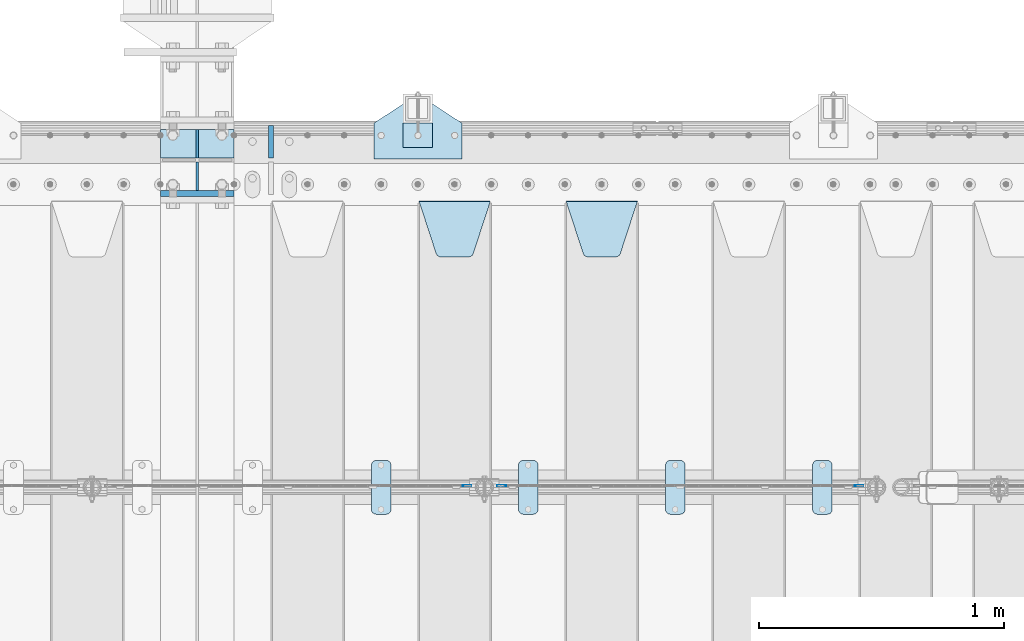
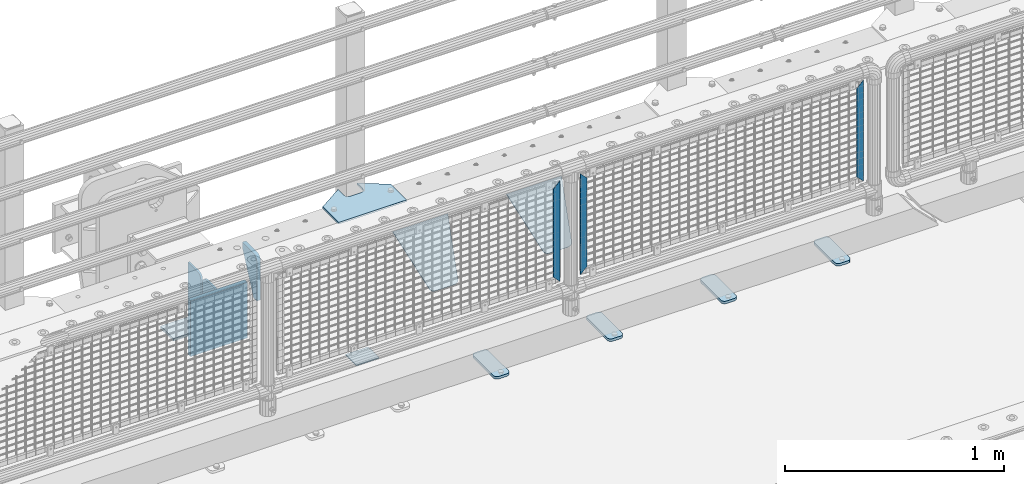
# One storey, part 221 of 247: 16 plates.
"""IFC2X3 building model written with IfcOpenShell, lengths in millimetres."""

from ifc_helpers import new_model, si_unit, frame, origin_with_axes, place, context, subcontext, project, spatial, faceted_brep, material, type_object, element, save


model = new_model("IFC2X3")

# Units and contexts
model_context = context("Model", 3, precision=1e-05, world=origin_with_axes())
body_context = subcontext(model_context, "Body", "Model", "MODEL_VIEW")
ifc_project = project(units=[si_unit("LENGTHUNIT", "METRE", prefix="MILLI"), si_unit("AREAUNIT", "SQUARE_METRE"), si_unit("VOLUMEUNIT", "CUBIC_METRE"), si_unit("MASSUNIT", "GRAM", prefix="KILO"), si_unit("TIMEUNIT", "SECOND"), si_unit("PLANEANGLEUNIT", "RADIAN"), si_unit("SOLIDANGLEUNIT", "STERADIAN"), si_unit("THERMODYNAMICTEMPERATUREUNIT", "DEGREE_CELSIUS"), si_unit("LUMINOUSINTENSITYUNIT", "LUMEN")], contexts=[model_context])

# Site, building, storey
site_placement = place(None, origin_with_axes())
site = spatial("IfcSite", under=ifc_project, at=site_placement, CompositionType="ELEMENT")
building_placement = place(site_placement, origin_with_axes())
building = spatial("IfcBuilding", under=site, at=building_placement, Name="Standard", CompositionType="ELEMENT")
storey_placement = place(building_placement, origin_with_axes())
storey = spatial("IfcBuildingStorey", under=building, at=storey_placement, Name="Undefined", CompositionType="ELEMENT", Elevation=0.0)

# Plates
ifc_material_1 = material(Name="STEEL/S355N")
plate_type_1 = type_object("IfcPlateType", PredefinedType="NOTDEFINED")
plate_1_placement = place(storey_placement, frame((12100.0, 8862.5, -340.0), z_axis=(0.0, 0.0, 1.0), x_axis=(1.0, 0.0, 0.0)))
element("IfcPlate", 1, at=plate_1_placement, inside=storey, type_object=plate_type_1, material=ifc_material_1, context=body_context, shape_type="Brep", body=[
    faceted_brep([(0.0, -12.5, 0.0), (0.0, -12.5, 310.0), (0.0, 12.5, 310.0), (0.0, 12.5, 0.0), (300.0, -12.5, 310.0), (300.0, 12.5, 310.0), (300.0, -12.5, 0.0), (300.0, 12.5, 0.0)], [[[0, 1, 2, 3]], [[1, 4, 5, 2]], [[4, 6, 7, 5]], [[6, 0, 3, 7]], [[5, 7, 3, 2]], [[6, 4, 1, 0]]]),
])
plate_type_2 = type_object("IfcPlateType", PredefinedType="NOTDEFINED")
plate_2_placement = place(storey_placement, frame((12100.0, 9008.0, -343.0), z_axis=(0.0, 1.0, 0.0), x_axis=(1.0, 0.0, 0.0)))
element("IfcPlate", 2, at=plate_2_placement, inside=storey, type_object=plate_type_2, material=ifc_material_1, context=body_context, shape_type="Brep", body=[
    faceted_brep([(0.0, -7.0, 0.0), (0.0, -7.0, 117.0), (0.0, 7.0, 117.0), (0.0, 7.0, 0.0), (300.0, -7.0, 117.0), (300.0, 7.0, 117.0), (300.0, -7.0, 0.0), (300.0, 7.0, 0.0)], [[[0, 1, 2, 3]], [[1, 4, 5, 2]], [[4, 6, 7, 5]], [[6, 0, 3, 7]], [[5, 7, 3, 2]], [[6, 4, 1, 0]]]),
])
plate_type_3 = type_object("IfcPlateType", PredefinedType="NOTDEFINED")
for number, where, z_axis, x_axis in (
    (3, (12250.0, 9008.0, -30.0), (0.0, 0.0, -1.0), (0.0, 1.0, 0.0)),
    (4, (12250.0, 8992.0, -30.0), (0.0, 0.0, -1.0), (0.0, -0.999999999999548, -9.5100000000016e-07)),
):
    element("IfcPlate", number, at=place(storey_placement, frame(where, z_axis=z_axis, x_axis=x_axis)), inside=storey, type_object=plate_type_3, material=ifc_material_1, context=body_context, shape_type="Brep", body=[
        faceted_brep([(0.0, -5.0, 30.0), (0.0, -5.0, 306.0), (0.0, 5.0, 306.0), (0.0, 5.0, 30.0), (117.0, -5.0, 306.0), (117.0, 5.0, 306.0), (117.0, -5.0, 0.0), (117.0, 5.0, 0.0), (30.0, -5.0, 0.0), (30.0, 5.0, 0.0), (24.7905546699922, -5.0, 0.455767409633758), (24.7905546699922, 5.0, 0.455767409633758), (19.73939570023, -5.0, 1.80922137642275), (19.73939570023, 5.0, 1.80922137642275), (15.0, -5.0, 4.01923788646684), (15.0, 5.0, 4.01923788646684), (10.716371709404, -5.0, 7.01866670643066), (10.716371709404, 5.0, 7.01866670643066), (7.01866670643085, -5.0, 10.7163717094038), (7.01866670643085, 5.0, 10.7163717094038), (4.01923788646673, -5.0, 15.0), (4.01923788646673, 5.0, 15.0), (1.80922137642256, -5.0, 19.7393957002299), (1.80922137642256, 5.0, 19.7393957002299), (0.455767409633609, -5.0, 24.7905546699921), (0.455767409633609, 5.0, 24.7905546699921)], [[[0, 1, 2, 3]], [[1, 4, 5, 2]], [[4, 6, 7, 5]], [[6, 8, 9, 7]], [[8, 10, 11, 9]], [[10, 12, 13, 11]], [[12, 14, 15, 13]], [[14, 16, 17, 15]], [[16, 18, 19, 17]], [[18, 20, 21, 19]], [[20, 22, 23, 21]], [[22, 24, 25, 23]], [[24, 0, 3, 25]], [[5, 7, 9, 11, 13, 15, 17, 19, 21, 23, 25, 3, 2]], [[24, 22, 20, 18, 16, 14, 12, 10, 8, 6, 4, 1, 0]]]),
    ])
ifc_material_2 = material(Name="STEEL/S355J2")
plate_type_4 = type_object("IfcPlateType", PredefinedType="NOTDEFINED")
plate_3_placement = place(storey_placement, frame((14760.0, 7774.5, 21.0199999999977), z_axis=(1.0, 0.0, 0.0), x_axis=(0.0, -0.999999999999548, -9.5100000000016e-07)))
element("IfcPlate", 5, at=plate_3_placement, inside=storey, type_object=plate_type_4, material=ifc_material_2, context=body_context, shape_type="Brep", body=[
    faceted_brep([(0.0, -7.0, 20.0), (0.0, -7.0, 60.0), (0.0, 7.0, 60.0), (0.0, 7.0, 20.0), (0.384294391935327, -7.0, 63.9018064403226), (0.384294391935327, 7.0, 63.9018064403226), (1.52240934977453, -7.0, 67.6536686473009), (1.52240934977453, 7.0, 67.6536686473009), (3.37060775394912, -7.0, 71.1114046603925), (3.37060775394912, 7.0, 71.1114046603925), (5.85786437626939, -7.0, 74.1421356237315), (5.85786437626939, 7.0, 74.1421356237315), (8.8885953396084, -7.0, 76.6293922460518), (8.8885953396084, 7.0, 76.6293922460518), (12.3463313526981, -7.0, 78.4775906502255), (12.3463313526981, 7.0, 78.4775906502255), (16.0981935596774, -7.0, 79.6157056080647), (16.0981935596774, 7.0, 79.6157056080647), (20.0, -7.0, 80.0), (20.0, 7.0, 80.0), (200.0, -7.0, 80.0), (200.0, 7.0, 80.0), (203.901806440323, -7.0, 79.6157056080647), (203.901806440323, 7.0, 79.6157056080647), (207.653668647302, -7.0, 78.4775906502255), (207.653668647302, 7.0, 78.4775906502255), (211.111404660392, -7.0, 76.6293922460518), (211.111404660392, 7.0, 76.6293922460518), (214.142135623731, -7.0, 74.1421356237315), (214.142135623731, 7.0, 74.1421356237315), (216.629392246051, -7.0, 71.1114046603925), (216.629392246051, 7.0, 71.1114046603925), (218.477590650225, -7.0, 67.6536686473009), (218.477590650225, 7.0, 67.6536686473009), (219.615705608065, -7.0, 63.9018064403226), (219.615705608065, 7.0, 63.9018064403226), (220.0, -7.0, 60.0), (220.0, 7.0, 60.0), (220.0, -7.0, 20.0), (220.0, 7.0, 20.0), (219.615705608065, -7.0, 16.0981935596774), (219.615705608065, 7.0, 16.0981935596774), (218.477590650225, -7.0, 12.3463313526991), (218.477590650225, 7.0, 12.3463313526991), (216.629392246051, -7.0, 8.88859533960749), (216.629392246051, 7.0, 8.88859533960749), (214.142135623731, -7.0, 5.85786437626848), (214.142135623731, 7.0, 5.85786437626848), (211.111404660392, -7.0, 3.37060775394821), (211.111404660392, 7.0, 3.37060775394821), (207.653668647302, -7.0, 1.52240934977453), (207.653668647302, 7.0, 1.52240934977453), (203.901806440323, -7.0, 0.384294391935327), (203.901806440323, 7.0, 0.384294391935327), (200.0, -7.0, 0.0), (200.0, 7.0, 0.0), (20.0, -7.0, 0.0), (20.0, 7.0, 0.0), (16.0981935596774, -7.0, 0.384294391935327), (16.0981935596774, 7.0, 0.384294391935327), (12.3463313526981, -7.0, 1.52240934977453), (12.3463313526981, 7.0, 1.52240934977453), (8.8885953396084, -7.0, 3.37060775394821), (8.8885953396084, 7.0, 3.37060775394821), (5.85786437626939, -7.0, 5.85786437626848), (5.85786437626939, 7.0, 5.85786437626848), (3.37060775394912, -7.0, 8.88859533960749), (3.37060775394912, 7.0, 8.88859533960749), (1.52240934977453, -7.0, 12.3463313526991), (1.52240934977453, 7.0, 12.3463313526991), (0.384294391935327, -7.0, 16.0981935596774), (0.384294391935327, 7.0, 16.0981935596774)], [[[0, 1, 2, 3]], [[1, 4, 5, 2]], [[4, 6, 7, 5]], [[6, 8, 9, 7]], [[8, 10, 11, 9]], [[10, 12, 13, 11]], [[12, 14, 15, 13]], [[14, 16, 17, 15]], [[16, 18, 19, 17]], [[18, 20, 21, 19]], [[20, 22, 23, 21]], [[22, 24, 25, 23]], [[24, 26, 27, 25]], [[26, 28, 29, 27]], [[28, 30, 31, 29]], [[30, 32, 33, 31]], [[32, 34, 35, 33]], [[34, 36, 37, 35]], [[36, 38, 39, 37]], [[38, 40, 41, 39]], [[40, 42, 43, 41]], [[42, 44, 45, 43]], [[44, 46, 47, 45]], [[46, 48, 49, 47]], [[48, 50, 51, 49]], [[50, 52, 53, 51]], [[52, 54, 55, 53]], [[54, 56, 57, 55]], [[56, 58, 59, 57]], [[58, 60, 61, 59]], [[60, 62, 63, 61]], [[62, 64, 65, 63]], [[64, 66, 67, 65]], [[66, 68, 69, 67]], [[68, 70, 71, 69]], [[70, 0, 3, 71]], [[5, 7, 9, 11, 13, 15, 17, 19, 21, 23, 25, 27, 29, 31, 33, 35, 37, 39, 41, 43, 45, 47, 49, 51, 53, 55, 57, 59, 61, 63, 65, 67, 69, 71, 3, 2]], [[70, 68, 66, 64, 62, 60, 58, 56, 54, 52, 50, 48, 46, 44, 42, 40, 38, 36, 34, 32, 30, 28, 26, 24, 22, 20, 18, 16, 14, 12, 10, 8, 6, 4, 1, 0]]]),
])
plate_4_placement = place(storey_placement, frame((14160.0, 7774.5, 21.0199999999977), z_axis=(1.0, 0.0, 0.0), x_axis=(0.0, -0.999999999999548, -9.5100000000016e-07)))
element("IfcPlate", 6, at=plate_4_placement, inside=storey, type_object=plate_type_4, material=ifc_material_2, context=body_context, shape_type="Brep", body=[
    faceted_brep([(0.0, -7.0, 20.0), (0.0, -7.0, 60.0), (0.0, 7.0, 60.0), (0.0, 7.0, 20.0), (0.384294391935327, -7.0, 63.9018064403226), (0.384294391935327, 7.0, 63.9018064403226), (1.52240934977453, -7.0, 67.6536686473009), (1.52240934977453, 7.0, 67.6536686473009), (3.37060775394912, -7.0, 71.1114046603925), (3.37060775394912, 7.0, 71.1114046603925), (5.85786437626939, -7.0, 74.1421356237315), (5.85786437626939, 7.0, 74.1421356237315), (8.8885953396084, -7.0, 76.6293922460518), (8.8885953396084, 7.0, 76.6293922460518), (12.3463313526981, -7.0, 78.4775906502255), (12.3463313526981, 7.0, 78.4775906502255), (16.0981935596774, -7.0, 79.6157056080647), (16.0981935596774, 7.0, 79.6157056080647), (20.0, -7.0, 80.0), (20.0, 7.0, 80.0), (200.0, -7.0, 80.0), (200.0, 7.0, 80.0), (203.901806440323, -7.0, 79.6157056080647), (203.901806440323, 7.0, 79.6157056080647), (207.653668647302, -7.0, 78.4775906502255), (207.653668647302, 7.0, 78.4775906502255), (211.111404660392, -7.0, 76.6293922460518), (211.111404660392, 7.0, 76.6293922460518), (214.142135623731, -7.0, 74.1421356237315), (214.142135623731, 7.0, 74.1421356237315), (216.629392246051, -7.0, 71.1114046603925), (216.629392246051, 7.0, 71.1114046603925), (218.477590650225, -7.0, 67.6536686473009), (218.477590650225, 7.0, 67.6536686473009), (219.615705608065, -7.0, 63.9018064403226), (219.615705608065, 7.0, 63.9018064403226), (220.0, -7.0, 60.0), (220.0, 7.0, 60.0), (220.0, -7.0, 20.0), (220.0, 7.0, 20.0), (219.615705608065, -7.0, 16.0981935596774), (219.615705608065, 7.0, 16.0981935596774), (218.477590650225, -7.0, 12.3463313526991), (218.477590650225, 7.0, 12.3463313526991), (216.629392246051, -7.0, 8.88859533960749), (216.629392246051, 7.0, 8.88859533960749), (214.142135623731, -7.0, 5.85786437626848), (214.142135623731, 7.0, 5.85786437626848), (211.111404660392, -7.0, 3.37060775394821), (211.111404660392, 7.0, 3.37060775394821), (207.653668647302, -7.0, 1.52240934977453), (207.653668647302, 7.0, 1.52240934977453), (203.901806440323, -7.0, 0.384294391935327), (203.901806440323, 7.0, 0.384294391935327), (200.0, -7.0, 0.0), (200.0, 7.0, 0.0), (20.0, -7.0, 0.0), (20.0, 7.0, 0.0), (16.0981935596774, -7.0, 0.384294391935327), (16.0981935596774, 7.0, 0.384294391935327), (12.3463313526981, -7.0, 1.52240934977453), (12.3463313526981, 7.0, 1.52240934977453), (8.8885953396084, -7.0, 3.37060775394821), (8.8885953396084, 7.0, 3.37060775394821), (5.85786437626939, -7.0, 5.85786437626848), (5.85786437626939, 7.0, 5.85786437626848), (3.37060775394912, -7.0, 8.88859533960749), (3.37060775394912, 7.0, 8.88859533960749), (1.52240934977453, -7.0, 12.3463313526991), (1.52240934977453, 7.0, 12.3463313526991), (0.384294391935327, -7.0, 16.0981935596774), (0.384294391935327, 7.0, 16.0981935596774)], [[[0, 1, 2, 3]], [[1, 4, 5, 2]], [[4, 6, 7, 5]], [[6, 8, 9, 7]], [[8, 10, 11, 9]], [[10, 12, 13, 11]], [[12, 14, 15, 13]], [[14, 16, 17, 15]], [[16, 18, 19, 17]], [[18, 20, 21, 19]], [[20, 22, 23, 21]], [[22, 24, 25, 23]], [[24, 26, 27, 25]], [[26, 28, 29, 27]], [[28, 30, 31, 29]], [[30, 32, 33, 31]], [[32, 34, 35, 33]], [[34, 36, 37, 35]], [[36, 38, 39, 37]], [[38, 40, 41, 39]], [[40, 42, 43, 41]], [[42, 44, 45, 43]], [[44, 46, 47, 45]], [[46, 48, 49, 47]], [[48, 50, 51, 49]], [[50, 52, 53, 51]], [[52, 54, 55, 53]], [[54, 56, 57, 55]], [[56, 58, 59, 57]], [[58, 60, 61, 59]], [[60, 62, 63, 61]], [[62, 64, 65, 63]], [[64, 66, 67, 65]], [[66, 68, 69, 67]], [[68, 70, 71, 69]], [[70, 0, 3, 71]], [[5, 7, 9, 11, 13, 15, 17, 19, 21, 23, 25, 27, 29, 31, 33, 35, 37, 39, 41, 43, 45, 47, 49, 51, 53, 55, 57, 59, 61, 63, 65, 67, 69, 71, 3, 2]], [[70, 68, 66, 64, 62, 60, 58, 56, 54, 52, 50, 48, 46, 44, 42, 40, 38, 36, 34, 32, 30, 28, 26, 24, 22, 20, 18, 16, 14, 12, 10, 8, 6, 4, 1, 0]]]),
])
plate_5_placement = place(storey_placement, frame((13560.0, 7774.5, 21.0199999999977), z_axis=(1.0, 0.0, 0.0), x_axis=(0.0, -0.999999999999548, -9.5100000000016e-07)))
element("IfcPlate", 7, at=plate_5_placement, inside=storey, type_object=plate_type_4, material=ifc_material_2, context=body_context, shape_type="Brep", body=[
    faceted_brep([(0.0, -7.0, 20.0), (0.0, -7.0, 60.0), (0.0, 7.0, 60.0), (0.0, 7.0, 20.0), (0.384294391935327, -7.0, 63.9018064403226), (0.384294391935327, 7.0, 63.9018064403226), (1.52240934977453, -7.0, 67.6536686473009), (1.52240934977453, 7.0, 67.6536686473009), (3.37060775394912, -7.0, 71.1114046603925), (3.37060775394912, 7.0, 71.1114046603925), (5.85786437626939, -7.0, 74.1421356237315), (5.85786437626939, 7.0, 74.1421356237315), (8.8885953396084, -7.0, 76.6293922460518), (8.8885953396084, 7.0, 76.6293922460518), (12.3463313526981, -7.0, 78.4775906502255), (12.3463313526981, 7.0, 78.4775906502255), (16.0981935596774, -7.0, 79.6157056080647), (16.0981935596774, 7.0, 79.6157056080647), (20.0, -7.0, 80.0), (20.0, 7.0, 80.0), (200.0, -7.0, 80.0), (200.0, 7.0, 80.0), (203.901806440323, -7.0, 79.6157056080647), (203.901806440323, 7.0, 79.6157056080647), (207.653668647302, -7.0, 78.4775906502255), (207.653668647302, 7.0, 78.4775906502255), (211.111404660392, -7.0, 76.6293922460518), (211.111404660392, 7.0, 76.6293922460518), (214.142135623731, -7.0, 74.1421356237315), (214.142135623731, 7.0, 74.1421356237315), (216.629392246051, -7.0, 71.1114046603925), (216.629392246051, 7.0, 71.1114046603925), (218.477590650225, -7.0, 67.6536686473009), (218.477590650225, 7.0, 67.6536686473009), (219.615705608065, -7.0, 63.9018064403226), (219.615705608065, 7.0, 63.9018064403226), (220.0, -7.0, 60.0), (220.0, 7.0, 60.0), (220.0, -7.0, 20.0), (220.0, 7.0, 20.0), (219.615705608065, -7.0, 16.0981935596774), (219.615705608065, 7.0, 16.0981935596774), (218.477590650225, -7.0, 12.3463313526991), (218.477590650225, 7.0, 12.3463313526991), (216.629392246051, -7.0, 8.88859533960749), (216.629392246051, 7.0, 8.88859533960749), (214.142135623731, -7.0, 5.85786437626848), (214.142135623731, 7.0, 5.85786437626848), (211.111404660392, -7.0, 3.37060775394821), (211.111404660392, 7.0, 3.37060775394821), (207.653668647302, -7.0, 1.52240934977453), (207.653668647302, 7.0, 1.52240934977453), (203.901806440323, -7.0, 0.384294391935327), (203.901806440323, 7.0, 0.384294391935327), (200.0, -7.0, 0.0), (200.0, 7.0, 0.0), (20.0, -7.0, 0.0), (20.0, 7.0, 0.0), (16.0981935596774, -7.0, 0.384294391935327), (16.0981935596774, 7.0, 0.384294391935327), (12.3463313526981, -7.0, 1.52240934977453), (12.3463313526981, 7.0, 1.52240934977453), (8.8885953396084, -7.0, 3.37060775394821), (8.8885953396084, 7.0, 3.37060775394821), (5.85786437626939, -7.0, 5.85786437626848), (5.85786437626939, 7.0, 5.85786437626848), (3.37060775394912, -7.0, 8.88859533960749), (3.37060775394912, 7.0, 8.88859533960749), (1.52240934977453, -7.0, 12.3463313526991), (1.52240934977453, 7.0, 12.3463313526991), (0.384294391935327, -7.0, 16.0981935596774), (0.384294391935327, 7.0, 16.0981935596774)], [[[0, 1, 2, 3]], [[1, 4, 5, 2]], [[4, 6, 7, 5]], [[6, 8, 9, 7]], [[8, 10, 11, 9]], [[10, 12, 13, 11]], [[12, 14, 15, 13]], [[14, 16, 17, 15]], [[16, 18, 19, 17]], [[18, 20, 21, 19]], [[20, 22, 23, 21]], [[22, 24, 25, 23]], [[24, 26, 27, 25]], [[26, 28, 29, 27]], [[28, 30, 31, 29]], [[30, 32, 33, 31]], [[32, 34, 35, 33]], [[34, 36, 37, 35]], [[36, 38, 39, 37]], [[38, 40, 41, 39]], [[40, 42, 43, 41]], [[42, 44, 45, 43]], [[44, 46, 47, 45]], [[46, 48, 49, 47]], [[48, 50, 51, 49]], [[50, 52, 53, 51]], [[52, 54, 55, 53]], [[54, 56, 57, 55]], [[56, 58, 59, 57]], [[58, 60, 61, 59]], [[60, 62, 63, 61]], [[62, 64, 65, 63]], [[64, 66, 67, 65]], [[66, 68, 69, 67]], [[68, 70, 71, 69]], [[70, 0, 3, 71]], [[5, 7, 9, 11, 13, 15, 17, 19, 21, 23, 25, 27, 29, 31, 33, 35, 37, 39, 41, 43, 45, 47, 49, 51, 53, 55, 57, 59, 61, 63, 65, 67, 69, 71, 3, 2]], [[70, 68, 66, 64, 62, 60, 58, 56, 54, 52, 50, 48, 46, 44, 42, 40, 38, 36, 34, 32, 30, 28, 26, 24, 22, 20, 18, 16, 14, 12, 10, 8, 6, 4, 1, 0]]]),
])
plate_6_placement = place(storey_placement, frame((12960.0, 7774.5, 21.0199999999977), z_axis=(1.0, 0.0, 0.0), x_axis=(0.0, -0.999999999999548, -9.5100000000016e-07)))
element("IfcPlate", 8, at=plate_6_placement, inside=storey, type_object=plate_type_4, material=ifc_material_2, context=body_context, shape_type="Brep", body=[
    faceted_brep([(0.0, -7.0, 20.0), (0.0, -7.0, 60.0), (0.0, 7.0, 60.0), (0.0, 7.0, 20.0), (0.384294391935327, -7.0, 63.9018064403226), (0.384294391935327, 7.0, 63.9018064403226), (1.52240934977453, -7.0, 67.6536686473009), (1.52240934977453, 7.0, 67.6536686473009), (3.37060775394912, -7.0, 71.1114046603925), (3.37060775394912, 7.0, 71.1114046603925), (5.85786437626939, -7.0, 74.1421356237315), (5.85786437626939, 7.0, 74.1421356237315), (8.8885953396084, -7.0, 76.6293922460518), (8.8885953396084, 7.0, 76.6293922460518), (12.3463313526981, -7.0, 78.4775906502255), (12.3463313526981, 7.0, 78.4775906502255), (16.0981935596774, -7.0, 79.6157056080647), (16.0981935596774, 7.0, 79.6157056080647), (20.0, -7.0, 80.0), (20.0, 7.0, 80.0), (200.0, -7.0, 80.0), (200.0, 7.0, 80.0), (203.901806440323, -7.0, 79.6157056080647), (203.901806440323, 7.0, 79.6157056080647), (207.653668647302, -7.0, 78.4775906502255), (207.653668647302, 7.0, 78.4775906502255), (211.111404660392, -7.0, 76.6293922460518), (211.111404660392, 7.0, 76.6293922460518), (214.142135623731, -7.0, 74.1421356237315), (214.142135623731, 7.0, 74.1421356237315), (216.629392246051, -7.0, 71.1114046603925), (216.629392246051, 7.0, 71.1114046603925), (218.477590650225, -7.0, 67.6536686473009), (218.477590650225, 7.0, 67.6536686473009), (219.615705608065, -7.0, 63.9018064403226), (219.615705608065, 7.0, 63.9018064403226), (220.0, -7.0, 60.0), (220.0, 7.0, 60.0), (220.0, -7.0, 20.0), (220.0, 7.0, 20.0), (219.615705608065, -7.0, 16.0981935596774), (219.615705608065, 7.0, 16.0981935596774), (218.477590650225, -7.0, 12.3463313526991), (218.477590650225, 7.0, 12.3463313526991), (216.629392246051, -7.0, 8.88859533960749), (216.629392246051, 7.0, 8.88859533960749), (214.142135623731, -7.0, 5.85786437626848), (214.142135623731, 7.0, 5.85786437626848), (211.111404660392, -7.0, 3.37060775394821), (211.111404660392, 7.0, 3.37060775394821), (207.653668647302, -7.0, 1.52240934977453), (207.653668647302, 7.0, 1.52240934977453), (203.901806440323, -7.0, 0.384294391935327), (203.901806440323, 7.0, 0.384294391935327), (200.0, -7.0, 0.0), (200.0, 7.0, 0.0), (20.0, -7.0, 0.0), (20.0, 7.0, 0.0), (16.0981935596774, -7.0, 0.384294391935327), (16.0981935596774, 7.0, 0.384294391935327), (12.3463313526981, -7.0, 1.52240934977453), (12.3463313526981, 7.0, 1.52240934977453), (8.8885953396084, -7.0, 3.37060775394821), (8.8885953396084, 7.0, 3.37060775394821), (5.85786437626939, -7.0, 5.85786437626848), (5.85786437626939, 7.0, 5.85786437626848), (3.37060775394912, -7.0, 8.88859533960749), (3.37060775394912, 7.0, 8.88859533960749), (1.52240934977453, -7.0, 12.3463313526991), (1.52240934977453, 7.0, 12.3463313526991), (0.384294391935327, -7.0, 16.0981935596774), (0.384294391935327, 7.0, 16.0981935596774)], [[[0, 1, 2, 3]], [[1, 4, 5, 2]], [[4, 6, 7, 5]], [[6, 8, 9, 7]], [[8, 10, 11, 9]], [[10, 12, 13, 11]], [[12, 14, 15, 13]], [[14, 16, 17, 15]], [[16, 18, 19, 17]], [[18, 20, 21, 19]], [[20, 22, 23, 21]], [[22, 24, 25, 23]], [[24, 26, 27, 25]], [[26, 28, 29, 27]], [[28, 30, 31, 29]], [[30, 32, 33, 31]], [[32, 34, 35, 33]], [[34, 36, 37, 35]], [[36, 38, 39, 37]], [[38, 40, 41, 39]], [[40, 42, 43, 41]], [[42, 44, 45, 43]], [[44, 46, 47, 45]], [[46, 48, 49, 47]], [[48, 50, 51, 49]], [[50, 52, 53, 51]], [[52, 54, 55, 53]], [[54, 56, 57, 55]], [[56, 58, 59, 57]], [[58, 60, 61, 59]], [[60, 62, 63, 61]], [[62, 64, 65, 63]], [[64, 66, 67, 65]], [[66, 68, 69, 67]], [[68, 70, 71, 69]], [[70, 0, 3, 71]], [[5, 7, 9, 11, 13, 15, 17, 19, 21, 23, 25, 27, 29, 31, 33, 35, 37, 39, 41, 43, 45, 47, 49, 51, 53, 55, 57, 59, 61, 63, 65, 67, 69, 71, 3, 2]], [[70, 68, 66, 64, 62, 60, 58, 56, 54, 52, 50, 48, 46, 44, 42, 40, 38, 36, 34, 32, 30, 28, 26, 24, 22, 20, 18, 16, 14, 12, 10, 8, 6, 4, 1, 0]]]),
])
plate_type_5 = type_object("IfcPlateType", PredefinedType="NOTDEFINED")
plate_7_placement = place(storey_placement, frame((13755.0, 8831.76776695594, -1.767766952965), z_axis=(0.0, -0.707106781186548, -0.707106781186547), x_axis=(1.0, 0.0, 0.0)))
element("IfcPlate", 9, at=plate_7_placement, inside=storey, type_object=plate_type_5, material=ifc_material_1, context=body_context, shape_type="Brep", body=[
    faceted_brep([(0.0, -2.49999999999909, 0.0), (69.345504679477, -2.5, 300.17173142483), (69.345504679477, 2.50000000000091, 300.171731424831), (0.0, 2.5, -9.09494701772928e-13), (70.9274061199576, -2.5, 304.897442415399), (70.9274061199576, 2.50000000000091, 304.8974424154), (73.3818627772307, -2.49999999999909, 309.234538108527), (73.3818627772307, 2.5, 309.234538108526), (76.6187032999551, -2.5, 313.023683126102), (76.6187032999551, 2.50000000000091, 313.023683126102), (80.5190132704993, -2.49999999999909, 316.125672595371), (80.5190132704993, 2.50000000000091, 316.125672595372), (84.9395038596849, -2.49999999999909, 318.426546230476), (84.9395038596849, 2.5, 318.426546230475), (89.7177759439219, -2.5, 319.841774983274), (89.7177759439219, 2.50000000000091, 319.841774983275), (94.678286292652, -2.5, 320.319366455077), (94.678286292652, 2.50000000000091, 320.319366455077), (195.321713707348, -2.5, 320.319366455077), (195.321713707348, 2.50000000000091, 320.319366455077), (200.282224056078, -2.5, 319.841774983274), (200.282224056078, 2.50000000000091, 319.841774983275), (205.060496140315, -2.5, 318.426546230475), (205.060496140315, 2.5, 318.426546230474), (209.480986729501, -2.49999999999818, 316.12567259537), (209.480986729501, 2.50000000000091, 316.12567259537), (213.381296700045, -2.5, 313.023683126101), (213.381296700045, 2.50000000000091, 313.023683126101), (216.618137222769, -2.5, 309.234538108525), (216.618137222769, 2.5, 309.234538108525), (219.072593880042, -2.49999999999909, 304.897442415398), (219.072593880042, 2.5, 304.897442415398), (220.654495320523, -2.5, 300.17173142483), (220.654495320523, 2.50000000000091, 300.171731424831), (290.0, -2.49999999999909, 0.0), (290.0, 2.5, -9.09494701772928e-13)], [[[0, 1, 2, 3]], [[1, 4, 5, 2]], [[4, 6, 7, 5]], [[6, 8, 9, 7]], [[8, 10, 11, 9]], [[10, 12, 13, 11]], [[12, 14, 15, 13]], [[14, 16, 17, 15]], [[16, 18, 19, 17]], [[18, 20, 21, 19]], [[20, 22, 23, 21]], [[22, 24, 25, 23]], [[24, 26, 27, 25]], [[26, 28, 29, 27]], [[28, 30, 31, 29]], [[30, 32, 33, 31]], [[32, 34, 35, 33]], [[34, 0, 3, 35]], [[5, 7, 9, 11, 13, 15, 17, 19, 21, 23, 25, 27, 29, 31, 33, 35, 3, 2]], [[34, 32, 30, 28, 26, 24, 22, 20, 18, 16, 14, 12, 10, 8, 6, 4, 1, 0]]]),
])
plate_8_placement = place(storey_placement, frame((13155.0, 8831.76776695594, -1.767766952965), z_axis=(0.0, -0.707106781186548, -0.707106781186547), x_axis=(1.0, 0.0, 0.0)))
element("IfcPlate", 10, at=plate_8_placement, inside=storey, type_object=plate_type_5, material=ifc_material_1, context=body_context, shape_type="Brep", body=[
    faceted_brep([(0.0, -2.49999999999909, 0.0), (69.345504679477, -2.5, 300.17173142483), (69.345504679477, 2.50000000000091, 300.171731424831), (0.0, 2.5, -9.09494701772928e-13), (70.9274061199576, -2.5, 304.897442415399), (70.9274061199576, 2.50000000000091, 304.8974424154), (73.3818627772307, -2.49999999999909, 309.234538108527), (73.3818627772307, 2.5, 309.234538108526), (76.6187032999551, -2.5, 313.023683126102), (76.6187032999551, 2.50000000000091, 313.023683126102), (80.5190132704993, -2.49999999999909, 316.125672595371), (80.5190132704993, 2.50000000000091, 316.125672595372), (84.9395038596849, -2.49999999999909, 318.426546230476), (84.9395038596849, 2.5, 318.426546230475), (89.7177759439219, -2.5, 319.841774983274), (89.7177759439219, 2.50000000000091, 319.841774983275), (94.678286292652, -2.5, 320.319366455077), (94.678286292652, 2.50000000000091, 320.319366455077), (195.321713707348, -2.5, 320.319366455077), (195.321713707348, 2.50000000000091, 320.319366455077), (200.282224056078, -2.5, 319.841774983274), (200.282224056078, 2.50000000000091, 319.841774983275), (205.060496140315, -2.5, 318.426546230475), (205.060496140315, 2.5, 318.426546230474), (209.480986729501, -2.49999999999818, 316.12567259537), (209.480986729501, 2.50000000000091, 316.12567259537), (213.381296700045, -2.5, 313.023683126101), (213.381296700045, 2.50000000000091, 313.023683126101), (216.618137222769, -2.5, 309.234538108525), (216.618137222769, 2.5, 309.234538108525), (219.072593880042, -2.49999999999909, 304.897442415398), (219.072593880042, 2.5, 304.897442415398), (220.654495320523, -2.5, 300.17173142483), (220.654495320523, 2.50000000000091, 300.171731424831), (290.0, -2.49999999999909, 0.0), (290.0, 2.5, -9.09494701772928e-13)], [[[0, 1, 2, 3]], [[1, 4, 5, 2]], [[4, 6, 7, 5]], [[6, 8, 9, 7]], [[8, 10, 11, 9]], [[10, 12, 13, 11]], [[12, 14, 15, 13]], [[14, 16, 17, 15]], [[16, 18, 19, 17]], [[18, 20, 21, 19]], [[20, 22, 23, 21]], [[22, 24, 25, 23]], [[24, 26, 27, 25]], [[26, 28, 29, 27]], [[28, 30, 31, 29]], [[30, 32, 33, 31]], [[32, 34, 35, 33]], [[34, 0, 3, 35]], [[5, 7, 9, 11, 13, 15, 17, 19, 21, 23, 25, 27, 29, 31, 33, 35, 3, 2]], [[34, 32, 30, 28, 26, 24, 22, 20, 18, 16, 14, 12, 10, 8, 6, 4, 1, 0]]]),
])
ifc_material_3 = material(Name="Misc_Undefined")
plate_type_6 = type_object("IfcPlateType", PredefinedType="NOTDEFINED")
plate_9_placement = place(storey_placement, frame((13509.509713541, 7670.5, 879.519963133601), z_axis=(-0.707008801899319, 0.0, -0.707204746899291), x_axis=(-0.707204746899294, 0.0, 0.707008801899315)))
element("IfcPlate", 11, at=plate_9_placement, inside=storey, type_object=plate_type_6, material=ifc_material_3, context=body_context, shape_type="Brep", body=[
    faceted_brep([(1.81898940354586e-12, -1.5, -5.6843418860808e-14), (-348.552185058596, -1.5, 348.655029296875), (-348.552185058596, 1.5, 348.655029296875), (1.81898940354586e-12, 1.5, -5.6843418860808e-14), (-348.544891357424, -1.5, 398.152496337891), (-348.544891357424, 1.5, 398.152496337891), (49.50439453125, -1.5, 7.6397554948926e-11), (49.50439453125, 1.5, 7.6397554948926e-11)], [[[0, 1, 2, 3]], [[1, 4, 5, 2]], [[4, 6, 7, 5]], [[6, 0, 3, 7]], [[5, 7, 3, 2]], [[6, 4, 1, 0]]]),
])
for number, where, z_axis, x_axis in (
    (12, (14932.4996874836, 7670.5, 879.52), (0.707103624179499, 0.0, -0.707109938179501), (0.707109938179497, 0.0, 0.707103624179503)),
    (13, (13332.4996874836, 7670.5, 879.52), (0.707103624179499, 0.0, -0.707109938179501), (0.707109938179497, 0.0, 0.707103624179503)),
):
    element("IfcPlate", number, at=place(storey_placement, frame(where, z_axis=z_axis, x_axis=x_axis)), inside=storey, type_object=plate_type_6, material=ifc_material_3, context=body_context, shape_type="Brep", body=[
        faceted_brep([(1.81898940354586e-12, -1.5, -5.6843418860808e-14), (-348.605163574215, -1.5, 348.60208129883), (-348.605163574215, 1.5, 348.60208129883), (1.81898940354586e-12, 1.5, -5.6843418860808e-14), (-348.605163574215, -1.5, 398.099334716799), (-348.605163574215, 1.5, 398.099334716799), (49.4976959228497, -1.5, 7.09405867382884e-11), (49.4976959228497, 1.5, 7.09405867382884e-11)], [[[0, 1, 2, 3]], [[1, 4, 5, 2]], [[4, 6, 7, 5]], [[6, 0, 3, 7]], [[5, 7, 3, 2]], [[6, 4, 1, 0]]]),
    ])
plate_type_7 = type_object("IfcPlateType", PredefinedType="NOTDEFINED")
plate_10_placement = place(storey_placement, frame((12550.0, 9140.0, -30.0), z_axis=(0.0, 0.0, -1.0), x_axis=(0.0, -0.999999999999548, -9.5100000000016e-07)))
element("IfcPlate", 14, at=plate_10_placement, inside=storey, type_object=plate_type_7, material=ifc_material_1, context=body_context, shape_type="Brep", body=[
    faceted_brep([(-5.6843418860808e-14, -9.99999999999989, 3.5527136788005e-15), (0.0, -10.0, 30.0), (0.0, 10.0, 30.0), (-5.6843418860808e-14, 10.0000000000001, 3.5527136788005e-15), (102.0, -10.0, 250.0), (102.0, 10.0, 250.0), (132.0, -10.0, 250.0), (132.0, 10.0, 250.0), (132.0, -10.0, 30.0), (132.0, 10.0, 30.0), (131.544232590366, -10.0, 24.790554669992), (131.544232590366, 10.0, 24.790554669992), (130.190778623577, -10.0, 19.7393957002299), (130.190778623577, 10.0, 19.7393957002299), (127.980762113533, -10.0, 15.0), (127.980762113533, 10.0, 15.0), (124.981333293569, -10.0, 10.7163717094038), (124.981333293569, 10.0, 10.7163717094038), (121.283628290596, -10.0, 7.01866670643062), (121.283628290596, 10.0, 7.01866670643062), (117.0, -10.0, 4.01923788646684), (117.0, 10.0, 4.01923788646684), (112.26060429977, -10.0, 1.80922137642278), (112.26060429977, 10.0, 1.80922137642278), (107.209445330008, -10.0, 0.455767409633722), (107.209445330008, 10.0, 0.455767409633722), (102.0, -10.0, 0.0), (102.0, 10.0, 0.0)], [[[0, 1, 2, 3]], [[1, 4, 5, 2]], [[4, 6, 7, 5]], [[6, 8, 9, 7]], [[8, 10, 11, 9]], [[10, 12, 13, 11]], [[12, 14, 15, 13]], [[14, 16, 17, 15]], [[16, 18, 19, 17]], [[18, 20, 21, 19]], [[20, 22, 23, 21]], [[22, 24, 25, 23]], [[24, 26, 27, 25]], [[26, 0, 3, 27]], [[5, 7, 9, 11, 13, 15, 17, 19, 21, 23, 25, 27, 3, 2]], [[26, 24, 22, 20, 18, 16, 14, 12, 10, 8, 6, 4, 1, 0]]]),
])
plate_type_8 = type_object("IfcPlateType", PredefinedType="NOTDEFINED")
plate_11_placement = place(storey_placement, frame((12970.0, 9005.0, 5.00000000004911), z_axis=(0.0, 1.0, 0.0), x_axis=(1.0, 0.0, 0.0)))
element("IfcPlate", 15, at=plate_11_placement, inside=storey, type_object=plate_type_8, material=ifc_material_2, context=body_context, shape_type="Brep", body=[
    faceted_brep([(9.04219632502645e-09, -5.00000000143385, -2.89173840428703e-09), (2.31396552408114e-06, -5.0, 145.0), (2.31396552408114e-06, 5.0, 145.0), (7.66340235713869e-09, 4.99999999856618, -2.89173840428703e-09), (130.0, -5.0, 230.0), (130.0, 5.0, 230.0), (130.0, -5.0, 180.0), (130.0, 5.0, 180.0), (130.48036798992, -5.0, 175.122741949597), (130.48036798992, 5.0, 175.122741949597), (131.903011687218, -5.0, 170.432914190873), (131.903011687218, 5.0, 170.432914190873), (134.213259692437, -5.0, 166.11074417451), (134.213259692437, 5.0, 166.11074417451), (137.322330470337, -5.0, 162.322330470337), (137.322330470337, 5.0, 162.322330470337), (141.11074417451, -5.0, 159.213259692437), (141.11074417451, 5.0, 159.213259692437), (145.432914190873, -5.0, 156.903011687218), (145.432914190873, 5.0, 156.903011687218), (150.122741949597, -5.0, 155.48036798992), (150.122741949597, 5.0, 155.48036798992), (155.0, -5.0, 155.0), (155.0, 5.0, 155.0), (205.0, -5.0, 155.0), (205.0, 5.0, 155.0), (209.877258050403, -5.0, 155.48036798992), (209.877258050403, 5.0, 155.48036798992), (214.567085809127, -5.0, 156.903011687218), (214.567085809127, 5.0, 156.903011687218), (218.88925582549, -5.0, 159.213259692437), (218.88925582549, 5.0, 159.213259692437), (222.677669529663, -5.0, 162.322330470337), (222.677669529663, 5.0, 162.322330470337), (225.786740307563, -5.0, 166.11074417451), (225.786740307563, 5.0, 166.11074417451), (228.096988312782, -5.0, 170.432914190873), (228.096988312782, 5.0, 170.432914190873), (229.51963201008, -5.0, 175.122741949597), (229.51963201008, 5.0, 175.122741949597), (230.0, -5.0, 180.0), (230.0, 5.0, 180.0), (230.0, -5.0, 230.0), (230.0, 5.0, 230.0), (360.0, -5.0, 145.0), (360.0, 5.0, 145.0), (360.0, -5.0, -7.27595761418343e-12), (360.0, 5.0, -7.27595761418343e-12)], [[[0, 1, 2, 3]], [[1, 4, 5, 2]], [[4, 6, 7, 5]], [[6, 8, 9, 7]], [[8, 10, 11, 9]], [[10, 12, 13, 11]], [[12, 14, 15, 13]], [[14, 16, 17, 15]], [[16, 18, 19, 17]], [[18, 20, 21, 19]], [[20, 22, 23, 21]], [[22, 24, 25, 23]], [[24, 26, 27, 25]], [[26, 28, 29, 27]], [[28, 30, 31, 29]], [[30, 32, 33, 31]], [[32, 34, 35, 33]], [[34, 36, 37, 35]], [[36, 38, 39, 37]], [[38, 40, 41, 39]], [[40, 42, 43, 41]], [[42, 44, 45, 43]], [[44, 46, 47, 45]], [[46, 0, 3, 47]], [[5, 7, 9, 11, 13, 15, 17, 19, 21, 23, 25, 27, 29, 31, 33, 35, 37, 39, 41, 43, 45, 47, 3, 2]], [[46, 44, 42, 40, 38, 36, 34, 32, 30, 28, 26, 24, 22, 20, 18, 16, 14, 12, 10, 8, 6, 4, 1, 0]]]),
])
plate_type_9 = type_object("IfcPlateType", PredefinedType="NOTDEFINED")
plate_12_placement = place(storey_placement, frame((13090.0000000001, 9050.00000000021, -857.500000000002), z_axis=(0.0, 1.0, 0.0), x_axis=(1.0, 0.0, 0.0)))
element("IfcPlate", 16, at=plate_12_placement, inside=storey, type_object=plate_type_9, material=ifc_material_2, context=body_context, shape_type="Brep", body=[
    faceted_brep([(0.0, -2.49999999999909, 0.0), (0.0, -2.5, 100.0), (0.0, 2.5, 100.0), (0.0, 2.5, -9.09494701772928e-13), (120.0, -2.5, 100.0), (120.0, 2.5, 100.0), (120.0, -2.5, 0.0), (120.0, 2.5, 0.0)], [[[0, 1, 2, 3]], [[1, 4, 5, 2]], [[4, 6, 7, 5]], [[6, 0, 3, 7]], [[5, 7, 3, 2]], [[6, 4, 1, 0]]]),
])

save(model, "model.ifc")
